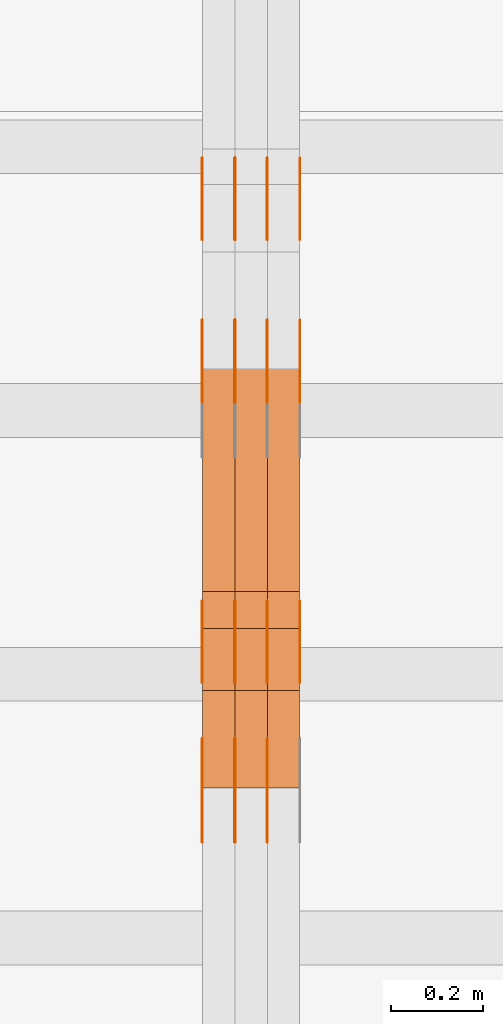
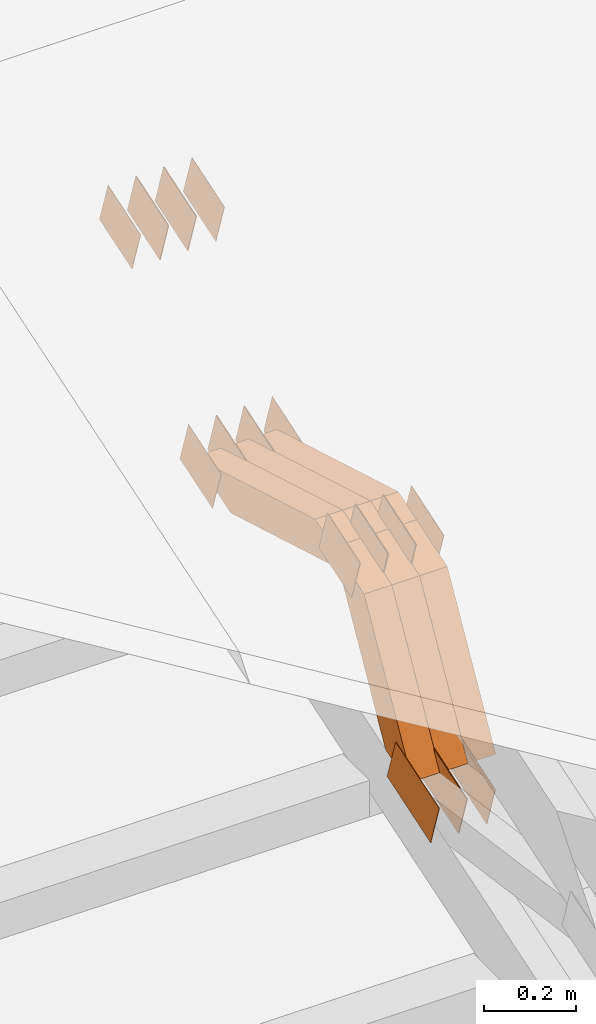
# One storey, part 109 of 385: 28 proxies.
"""IFC2X3 building model written with IfcOpenShell, lengths in millimetres."""

import ifcopenshell
import ifcopenshell.guid

model = None  # the IFC model being written
_history = None  # IfcOwnerHistory: only IFC2X3 demands one
_inside = {}  # id of a spatial element -> (the spatial element, [elements in it])
_under = {}  # id of a project, library or spatial element -> (it, [spatial elements below it])
_declared = {}  # id of a project -> (the project, [libraries it declares])
_typed = {}  # id of a type object -> (the type object, [elements of that type])
_made_of = {}  # id of a material, layer set ... -> (it, [elements and type objects made of it])


def new_model(schema):
    """Start an empty IFC model of exactly this schema.

    Asked for "IFC4X3", IfcOpenShell would pick the latest addendum, in which some entities
    have other attributes; the version numbers below select the first issue.
    IFC2X3 requires an IfcOwnerHistory on every rooted entity: one is made here for all.
    """
    global model, _history
    if schema == "IFC4X3":
        model = ifcopenshell.file(schema_version=(4, 3, 0, 0))
    else:
        model = ifcopenshell.file(schema=schema)
    _inside.clear()
    _under.clear()
    _declared.clear()
    _typed.clear()
    _made_of.clear()
    _history = None
    if model.schema == "IFC2X3":
        org = make("IfcOrganization", Name="unknown")
        user = make(
            "IfcPersonAndOrganization",
            ThePerson=make("IfcPerson", FamilyName="unknown"),
            TheOrganization=org,
        )
        app = make(
            "IfcApplication",
            ApplicationDeveloper=org,
            Version="unknown",
            ApplicationFullName="unknown",
            ApplicationIdentifier="unknown",
        )
        _history = make(
            "IfcOwnerHistory",
            OwningUser=user,
            OwningApplication=app,
            ChangeAction="ADDED",
            CreationDate=0,
        )
    return model


def make(cls, **values):
    """One entity of the class cls with the attributes given. An attribute that is None is left unset."""
    return model.create_entity(
        cls, **{name: value for name, value in values.items() if value is not None}
    )


def entity(cls, *values):
    """Any entity or typed value of the class cls, its attributes in the order of the schema. None: left unset."""
    e = model.create_entity(cls)
    for i, value in enumerate(values):
        if value is not None:
            e[i] = value
    return e


def rooted(cls, **values):
    """An entity with a GlobalId (a new one), such as an element, a storey or a relation."""
    return make(cls, GlobalId=ifcopenshell.guid.new(), OwnerHistory=_history, **values)


def si_unit(unit_type, name, prefix=None):
    """IfcSIUnit, for example si_unit("LENGTHUNIT", "METRE", prefix="MILLI")."""
    return make("IfcSIUnit", UnitType=unit_type, Prefix=prefix, Name=name)


def converted_unit(unit_type, name, factor, base, dimensions=None, offset=None):
    """IfcConversionBasedUnit, such as the inch: factor (a typed value) times the base unit."""
    return make(
        "IfcConversionBasedUnit"
        if offset is None
        else "IfcConversionBasedUnitWithOffset",
        ConversionOffset=offset,
        Dimensions=None
        if dimensions is None
        else entity("IfcDimensionalExponents", *dimensions),
        UnitType=unit_type,
        Name=name,
        ConversionFactor=make(
            "IfcMeasureWithUnit", ValueComponent=factor, UnitComponent=base
        ),
    )


def derived_unit(unit_type, elements):
    """IfcDerivedUnit: a product of units, each with its exponent."""
    return make(
        "IfcDerivedUnit",
        Elements=[
            make("IfcDerivedUnitElement", Unit=unit, Exponent=power)
            for unit, power in elements
        ],
        UnitType=unit_type,
    )


def assignment(units):
    """IfcUnitAssignment: the units of a project."""
    return None if units is None else make("IfcUnitAssignment", Units=units)


def point(xyz):
    """IfcCartesianPoint."""
    return None if xyz is None else make("IfcCartesianPoint", Coordinates=xyz)


def direction(xyz):
    """IfcDirection."""
    return None if xyz is None else make("IfcDirection", DirectionRatios=xyz)


def frame(location, z_axis=None, x_axis=None):
    """IfcAxis2Placement3D, a coordinate frame: its origin and axes. An axis left out is left unset."""
    return make(
        "IfcAxis2Placement3D",
        Location=point(location),
        Axis=direction(z_axis),
        RefDirection=direction(x_axis),
    )


def origin():
    """The frame at (0, 0, 0) with its axes left unset."""
    return frame((0.0, 0.0, 0.0))


def place(relative_to, where):
    """IfcLocalPlacement: puts the frame where relative to a parent placement (None: the world)."""
    return make(
        "IfcLocalPlacement", PlacementRelTo=relative_to, RelativePlacement=where
    )


def context(
    kind, dimensions, precision=None, world=None, true_north=None, identifier=None
):
    """IfcGeometricRepresentationContext, for example the 3D "Model" context."""
    return make(
        "IfcGeometricRepresentationContext",
        ContextIdentifier=identifier,
        ContextType=kind,
        CoordinateSpaceDimension=dimensions,
        Precision=precision,
        WorldCoordinateSystem=world,
        TrueNorth=true_north,
    )


def subcontext(parent, identifier, kind, view, scale=None):
    """IfcGeometricRepresentationSubContext, for example "Body" below "Model"."""
    return make(
        "IfcGeometricRepresentationSubContext",
        ContextIdentifier=identifier,
        ContextType=kind,
        ParentContext=parent,
        TargetScale=scale,
        TargetView=view,
    )


def project(units=None, contexts=None):
    """IfcProject with its units and contexts."""
    return rooted(
        "IfcProject",
        Name="project",
        RepresentationContexts=contexts,
        UnitsInContext=assignment(units),
    )


def spatial(cls, under=None, at=None, **own):
    """A site, building, storey or space (cls), placed at a placement, below another one or the project."""
    s = rooted(cls, ObjectPlacement=at, **own)
    if under is not None:
        _under.setdefault(under.id(), (under, []))[1].append(s)
    return s


def polyline(points):
    """IfcPolyline through the points."""
    return make("IfcPolyline", Points=[point(p) for p in points])


def outline(outer, holes=None, kind="AREA"):
    """IfcArbitraryClosedProfileDef: a profile drawn as a closed curve; with holes, ...WithVoids."""
    if holes is None:
        return make("IfcArbitraryClosedProfileDef", ProfileType=kind, OuterCurve=outer)
    return make(
        "IfcArbitraryProfileDefWithVoids",
        ProfileType=kind,
        OuterCurve=outer,
        InnerCurves=holes,
    )


def extrude(swept, where, along, depth):
    """IfcExtrudedAreaSolid: the profile swept, set in the frame where, extruded along a direction by depth."""
    return make(
        "IfcExtrudedAreaSolid",
        SweptArea=swept,
        Position=where,
        ExtrudedDirection=direction(along),
        Depth=depth,
    )


def shape(context_of_items, identifier, shape_type, items):
    """IfcShapeRepresentation: the items that make up one representation, for example the "Body"."""
    return make(
        "IfcShapeRepresentation",
        ContextOfItems=context_of_items,
        RepresentationIdentifier=identifier,
        RepresentationType=shape_type,
        Items=items,
    )


def source(mapping_origin, context_of_items, identifier, shape_type, items):
    """IfcRepresentationMap: a shape defined once, which mapped items show again and again."""
    return make(
        "IfcRepresentationMap",
        MappingOrigin=mapping_origin,
        MappedRepresentation=shape(context_of_items, identifier, shape_type, items),
    )


def transform(
    local_origin,
    x_axis=None,
    y_axis=None,
    z_axis=None,
    scale=None,
    scale2=None,
    scale3=None,
    uniform=True,
):
    """IfcCartesianTransformationOperator3D, or its non-uniform kind. x_axis, y_axis, z_axis: its Axis1, 2, 3."""
    if uniform:
        return make(
            "IfcCartesianTransformationOperator3D",
            Axis1=direction(x_axis),
            Axis2=direction(y_axis),
            LocalOrigin=point(local_origin),
            Scale=scale,
            Axis3=direction(z_axis),
        )
    return make(
        "IfcCartesianTransformationOperator3DnonUniform",
        Axis1=direction(x_axis),
        Axis2=direction(y_axis),
        LocalOrigin=point(local_origin),
        Scale=scale,
        Axis3=direction(z_axis),
        Scale2=scale2,
        Scale3=scale3,
    )


def mapped(mapping_source, mapping_target):
    """IfcMappedItem: shows the shape of a source again, moved by a transform."""
    return make(
        "IfcMappedItem", MappingSource=mapping_source, MappingTarget=mapping_target
    )


def material(Name=None, Category=None):
    """IfcMaterial."""
    return make("IfcMaterial", Name=Name, Category=Category)


def made_of(thing, what):
    """Note that an element or type object is made of a material, layer set ...; save() writes the relation."""
    if what is not None:
        _made_of.setdefault(what.id(), (what, []))[1].append(thing)
    return thing


def type_object(cls, material=None, **own):
    """A type object (cls), such as IfcWallType, which elements share."""
    return made_of(rooted(cls, **own), material)


def type_shapes(of_type, sources):
    """Give a type object the sources (RepresentationMaps) that its elements show as mapped items."""
    of_type.RepresentationMaps = sources


def element(
    cls,
    number,
    at=None,
    inside=None,
    cuts=None,
    type_object=None,
    material=None,
    context=None,
    identifier="Body",
    shape_type=None,
    held_by="IfcProductDefinitionShape",
    body=None,
    shapes=None,
    **own,
):
    """One element of the class cls, such as IfcWall. Its Tag is "e" and its number.

    at: its placement. inside: the storey or other place that contains it. cuts: it is an
    opening in that element (IfcRelVoidsElement). A single representation is given by context,
    identifier, shape_type and body (its items); several are given by shapes. held_by: the class
    of the entity that holds the representations. save() writes the other relations.
    """
    e = rooted(cls, Tag="e%d" % number, ObjectPlacement=at, **own)
    if body is not None:
        shapes = [shape(context, identifier, shape_type, body)]
    if shapes is not None:
        e.Representation = make(held_by, Representations=shapes)
    if inside is not None:
        _inside.setdefault(inside.id(), (inside, []))[1].append(e)
    if cuts is not None:
        rooted(
            "IfcRelVoidsElement", RelatingBuildingElement=cuts, RelatedOpeningElement=e
        )
    if type_object is not None:
        _typed.setdefault(type_object.id(), (type_object, []))[1].append(e)
    return made_of(e, material)


def aggregate(whole, parts):
    """IfcRelAggregates: a whole, such as a stair, and the parts it consists of."""
    return rooted("IfcRelAggregates", RelatingObject=whole, RelatedObjects=parts)


def save(model, path):
    """Write the relations noted so far, then the file.

    IfcRelAggregates (storeys below a building ...), IfcRelContainedInSpatialStructure (elements
    in a storey), IfcRelDefinesByType, IfcRelAssociatesMaterial and IfcRelDeclares: one each for
    every whole, place, type object, material and project.
    """
    for whole, parts in _under.values():
        aggregate(whole, parts)
    for where, things in _inside.values():
        rooted(
            "IfcRelContainedInSpatialStructure",
            RelatedElements=things,
            RelatingStructure=where,
        )
    for kind, things in _typed.values():
        rooted("IfcRelDefinesByType", RelatedObjects=things, RelatingType=kind)
    for what, things in _made_of.values():
        rooted("IfcRelAssociatesMaterial", RelatedObjects=things, RelatingMaterial=what)
    for by, libraries in _declared.values():
        rooted("IfcRelDeclares", RelatingContext=by, RelatedDefinitions=libraries)
    model.write(path)


model = new_model("IFC2X3")

# Units and contexts
model_context = context("Model", 3, precision=0.01, world=origin(), true_north=direction((6.12303176911189e-17, 1.0)))
body_context = subcontext(model_context, "Body", "Model", "MODEL_VIEW")
ifc_project = project(units=[si_unit("LENGTHUNIT", "METRE", prefix="MILLI"), si_unit("AREAUNIT", "SQUARE_METRE"), si_unit("VOLUMEUNIT", "CUBIC_METRE"), converted_unit("PLANEANGLEUNIT", "DEGREE", entity("IfcRatioMeasure", 0.0174532925199433), si_unit("PLANEANGLEUNIT", "RADIAN"), dimensions=[0, 0, 0, 0, 0, 0, 0]), si_unit("MASSUNIT", "GRAM", prefix="KILO"), derived_unit("MASSDENSITYUNIT", [(si_unit("MASSUNIT", "GRAM", prefix="KILO"), 1), (si_unit("LENGTHUNIT", "METRE"), -3)]), si_unit("TIMEUNIT", "SECOND"), si_unit("FREQUENCYUNIT", "HERTZ"), si_unit("THERMODYNAMICTEMPERATUREUNIT", "DEGREE_CELSIUS"), derived_unit("THERMALTRANSMITTANCEUNIT", [(si_unit("MASSUNIT", "GRAM", prefix="KILO"), 1), (si_unit("THERMODYNAMICTEMPERATUREUNIT", "KELVIN"), -1), (si_unit("TIMEUNIT", "SECOND"), -3)]), derived_unit("VOLUMETRICFLOWRATEUNIT", [(si_unit("LENGTHUNIT", "METRE"), 3), (si_unit("TIMEUNIT", "SECOND"), -1)]), si_unit("ELECTRICCURRENTUNIT", "AMPERE"), si_unit("ELECTRICVOLTAGEUNIT", "VOLT"), si_unit("POWERUNIT", "WATT"), si_unit("FORCEUNIT", "NEWTON", prefix="KILO"), si_unit("ILLUMINANCEUNIT", "LUX"), si_unit("LUMINOUSFLUXUNIT", "LUMEN"), si_unit("LUMINOUSINTENSITYUNIT", "CANDELA"), derived_unit("USERDEFINED", [(si_unit("MASSUNIT", "GRAM", prefix="KILO"), -1), (si_unit("LENGTHUNIT", "METRE"), -2), (si_unit("TIMEUNIT", "SECOND"), 3), (si_unit("LUMINOUSFLUXUNIT", "LUMEN"), 1)]), derived_unit("LINEARVELOCITYUNIT", [(si_unit("LENGTHUNIT", "METRE"), 1), (si_unit("TIMEUNIT", "SECOND"), -1)]), si_unit("PRESSUREUNIT", "PASCAL"), derived_unit("USERDEFINED", [(si_unit("LENGTHUNIT", "METRE"), -2), (si_unit("MASSUNIT", "GRAM", prefix="KILO"), 1), (si_unit("TIMEUNIT", "SECOND"), -2)])], contexts=[model_context])

# Site, building, storey
site_placement = place(None, origin())
site = spatial("IfcSite", under=ifc_project, at=site_placement, CompositionType="ELEMENT")
building_placement = place(site_placement, origin())
building = spatial("IfcBuilding", under=site, at=building_placement, CompositionType="ELEMENT")
storey_placement = place(building_placement, origin())
storey = spatial("IfcBuildingStorey", under=building, at=storey_placement, Name="Default", CompositionType="ELEMENT", Elevation=0.0)

# Proxies
ifc_material_1 = material(Name="IfcSurfaceStyle #236276")
building_element_proxy_type_1 = type_object("IfcBuildingElementProxyType", PredefinedType="NOTDEFINED", material=ifc_material_1)
shared_shape_1 = source(origin(), body_context, "Body", "SweptSolid", [
    extrude(outline(polyline([(-99.9998204243802, -60.000067376167), (99.9998338462265, -60.000067376167), (99.9998204243802, 60.000067376167), (-99.9998338462265, 60.000067376167), (-99.9998204243802, -60.000067376167)])), frame((100.000602015329, 60.0001864986889, 0.0), z_axis=(0.0, 0.0, 1.0), x_axis=(-1.0, 0.0, 0.0)), (0.0, 0.0, 1.0), 1.3),
])
type_shapes(building_element_proxy_type_1, [shared_shape_1])
proxy_1_placement = place(building_placement, frame((18316.3, 4114.85465165112, 513.097031388771), z_axis=(-1.0, 0.0, 0.0), x_axis=(0.0, 0.951056516295124, 0.309016994375039)))
element("IfcBuildingElementProxy", 1, at=proxy_1_placement, inside=storey, type_object=building_element_proxy_type_1, material=ifc_material_1, context=body_context, shape_type="MappedRepresentation", body=[
    mapped(shared_shape_1, transform((0.0, 0.0, 0.0), scale=1.0)),
])
ifc_material_2 = material(Name="IfcSurfaceStyle #236219")
building_element_proxy_type_2 = type_object("IfcBuildingElementProxyType", PredefinedType="NOTDEFINED", material=ifc_material_2)
shared_shape_2 = source(origin(), body_context, "Body", "SweptSolid", [
    extrude(outline(polyline([(-99.9998204243802, -60.000067376167), (99.9998338462265, -60.000067376167), (99.9998204243802, 60.000067376167), (-99.9998338462265, 60.000067376167), (-99.9998204243802, -60.000067376167)])), frame((100.000602015329, 60.0001864986889, 0.0), z_axis=(0.0, 0.0, 1.0), x_axis=(-1.0, 0.0, 0.0)), (0.0, 0.0, 1.0), 1.29999999999998),
])
type_shapes(building_element_proxy_type_2, [shared_shape_2])
proxy_2_placement = place(building_placement, frame((18245.0, 4114.85465165112, 513.097031388771), z_axis=(-1.0, 0.0, 0.0), x_axis=(0.0, 0.951056516295124, 0.309016994375039)))
element("IfcBuildingElementProxy", 2, at=proxy_2_placement, inside=storey, type_object=building_element_proxy_type_2, material=ifc_material_2, context=body_context, shape_type="MappedRepresentation", body=[
    mapped(shared_shape_2, transform((0.0, 0.0, 0.0), scale=1.0)),
])
ifc_material_3 = material(Name="IfcSurfaceStyle #236162")
building_element_proxy_type_3 = type_object("IfcBuildingElementProxyType", PredefinedType="NOTDEFINED", material=ifc_material_3)
shared_shape_3 = source(origin(), body_context, "Body", "SweptSolid", [
    extrude(outline(polyline([(-99.9998204243802, -60.000067376167), (99.9998338462265, -60.000067376167), (99.9998204243802, 60.000067376167), (-99.9998338462265, 60.000067376167), (-99.9998204243802, -60.000067376167)])), frame((100.000602015329, 60.0001864986889, 0.0), z_axis=(0.0, 0.0, 1.0), x_axis=(-1.0, 0.0, 0.0)), (0.0, 0.0, 1.0), 1.29999999999998),
])
type_shapes(building_element_proxy_type_3, [shared_shape_3])
proxy_3_placement = place(building_placement, frame((18246.3, 4114.85465165112, 513.097031388771), z_axis=(-1.0, 0.0, 0.0), x_axis=(0.0, 0.951056516295124, 0.309016994375039)))
element("IfcBuildingElementProxy", 3, at=proxy_3_placement, inside=storey, type_object=building_element_proxy_type_3, material=ifc_material_3, context=body_context, shape_type="MappedRepresentation", body=[
    mapped(shared_shape_3, transform((0.0, 0.0, 0.0), scale=1.0)),
])
ifc_material_4 = material(Name="IfcSurfaceStyle #236105")
building_element_proxy_type_4 = type_object("IfcBuildingElementProxyType", PredefinedType="NOTDEFINED", material=ifc_material_4)
shared_shape_4 = source(origin(), body_context, "Body", "SweptSolid", [
    extrude(outline(polyline([(-99.9998204243802, -60.000067376167), (99.9998338462265, -60.000067376167), (99.9998204243802, 60.000067376167), (-99.9998338462265, 60.000067376167), (-99.9998204243802, -60.000067376167)])), frame((100.000602015329, 60.0001864986889, 0.0), z_axis=(0.0, 0.0, 1.0), x_axis=(-1.0, 0.0, 0.0)), (0.0, 0.0, 1.0), 1.29999999999999),
])
type_shapes(building_element_proxy_type_4, [shared_shape_4])
proxy_4_placement = place(building_placement, frame((18175.0, 4114.85465165112, 513.097031388771), z_axis=(-1.0, 0.0, 0.0), x_axis=(0.0, 0.951056516295124, 0.309016994375039)))
element("IfcBuildingElementProxy", 4, at=proxy_4_placement, inside=storey, type_object=building_element_proxy_type_4, material=ifc_material_4, context=body_context, shape_type="MappedRepresentation", body=[
    mapped(shared_shape_4, transform((0.0, 0.0, 0.0), scale=1.0)),
])
ifc_material_5 = material(Name="IfcSurfaceStyle #236048")
building_element_proxy_type_5 = type_object("IfcBuildingElementProxyType", PredefinedType="NOTDEFINED", material=ifc_material_5)
shared_shape_5 = source(origin(), body_context, "Body", "SweptSolid", [
    extrude(outline(polyline([(-74.9998707133927, -60.0000596852269), (74.9998841352353, -60.0000596852269), (74.999861282944, 60.0000596852269), (-74.9998747047866, 60.0000596852269), (-74.9998707133927, -60.0000596852269)])), frame((74.9998841352353, 60.0000596852269, 0.0), z_axis=(0.0, 0.0, 1.0), x_axis=(-1.0, 0.0, 0.0)), (0.0, 0.0, 1.0), 1.3),
])
type_shapes(building_element_proxy_type_5, [shared_shape_5])
proxy_5_placement = place(building_placement, frame((18386.3, 5067.4882362875, 826.131473120182), z_axis=(-1.0, 0.0, 0.0), x_axis=(0.0, 0.951056516295124, 0.309016994375039)))
element("IfcBuildingElementProxy", 5, at=proxy_5_placement, inside=storey, type_object=building_element_proxy_type_5, material=ifc_material_5, context=body_context, shape_type="MappedRepresentation", body=[
    mapped(shared_shape_5, transform((0.0, 0.0, 0.0), scale=1.0)),
])
ifc_material_6 = material(Name="IfcSurfaceStyle #235991")
building_element_proxy_type_6 = type_object("IfcBuildingElementProxyType", PredefinedType="NOTDEFINED", material=ifc_material_6)
shared_shape_6 = source(origin(), body_context, "Body", "SweptSolid", [
    extrude(outline(polyline([(-74.9998707133927, -60.0000596852269), (74.9998841352353, -60.0000596852269), (74.999861282944, 60.0000596852269), (-74.9998747047866, 60.0000596852269), (-74.9998707133927, -60.0000596852269)])), frame((74.9998841352353, 60.0000596852269, 0.0), z_axis=(0.0, 0.0, 1.0), x_axis=(-1.0, 0.0, 0.0)), (0.0, 0.0, 1.0), 1.3),
])
type_shapes(building_element_proxy_type_6, [shared_shape_6])
proxy_6_placement = place(building_placement, frame((18315.0, 5067.4882362875, 826.131473120182), z_axis=(-1.0, 0.0, 0.0), x_axis=(0.0, 0.951056516295124, 0.309016994375039)))
element("IfcBuildingElementProxy", 6, at=proxy_6_placement, inside=storey, type_object=building_element_proxy_type_6, material=ifc_material_6, context=body_context, shape_type="MappedRepresentation", body=[
    mapped(shared_shape_6, transform((0.0, 0.0, 0.0), scale=1.0)),
])
ifc_material_7 = material(Name="IfcSurfaceStyle #235934")
building_element_proxy_type_7 = type_object("IfcBuildingElementProxyType", PredefinedType="NOTDEFINED", material=ifc_material_7)
shared_shape_7 = source(origin(), body_context, "Body", "SweptSolid", [
    extrude(outline(polyline([(-74.9998707133927, -60.0000596852269), (74.9998841352353, -60.0000596852269), (74.999861282944, 60.0000596852269), (-74.9998747047866, 60.0000596852269), (-74.9998707133927, -60.0000596852269)])), frame((74.9998841352353, 60.0000596852269, 0.0), z_axis=(0.0, 0.0, 1.0), x_axis=(-1.0, 0.0, 0.0)), (0.0, 0.0, 1.0), 1.3),
])
type_shapes(building_element_proxy_type_7, [shared_shape_7])
proxy_7_placement = place(building_placement, frame((18316.3, 5067.4882362875, 826.131473120182), z_axis=(-1.0, 0.0, 0.0), x_axis=(0.0, 0.951056516295124, 0.309016994375039)))
element("IfcBuildingElementProxy", 7, at=proxy_7_placement, inside=storey, type_object=building_element_proxy_type_7, material=ifc_material_7, context=body_context, shape_type="MappedRepresentation", body=[
    mapped(shared_shape_7, transform((0.0, 0.0, 0.0), scale=1.0)),
])
ifc_material_8 = material(Name="IfcSurfaceStyle #235877")
building_element_proxy_type_8 = type_object("IfcBuildingElementProxyType", PredefinedType="NOTDEFINED", material=ifc_material_8)
shared_shape_8 = source(origin(), body_context, "Body", "SweptSolid", [
    extrude(outline(polyline([(-74.9998707133927, -60.0000596852269), (74.9998841352353, -60.0000596852269), (74.999861282944, 60.0000596852269), (-74.9998747047866, 60.0000596852269), (-74.9998707133927, -60.0000596852269)])), frame((74.9998841352353, 60.0000596852269, 0.0), z_axis=(0.0, 0.0, 1.0), x_axis=(-1.0, 0.0, 0.0)), (0.0, 0.0, 1.0), 1.29999999999999),
])
type_shapes(building_element_proxy_type_8, [shared_shape_8])
proxy_8_placement = place(building_placement, frame((18245.0, 5067.4882362875, 826.131473120182), z_axis=(-1.0, 0.0, 0.0), x_axis=(0.0, 0.951056516295124, 0.309016994375039)))
element("IfcBuildingElementProxy", 8, at=proxy_8_placement, inside=storey, type_object=building_element_proxy_type_8, material=ifc_material_8, context=body_context, shape_type="MappedRepresentation", body=[
    mapped(shared_shape_8, transform((0.0, 0.0, 0.0), scale=1.0)),
])
ifc_material_9 = material(Name="IfcSurfaceStyle #235820")
building_element_proxy_type_9 = type_object("IfcBuildingElementProxyType", PredefinedType="NOTDEFINED", material=ifc_material_9)
shared_shape_9 = source(origin(), body_context, "Body", "SweptSolid", [
    extrude(outline(polyline([(-74.9998707133927, -60.0000596852269), (74.9998841352353, -60.0000596852269), (74.999861282944, 60.0000596852269), (-74.9998747047866, 60.0000596852269), (-74.9998707133927, -60.0000596852269)])), frame((74.9998841352353, 60.0000596852269, 0.0), z_axis=(0.0, 0.0, 1.0), x_axis=(-1.0, 0.0, 0.0)), (0.0, 0.0, 1.0), 1.29999999999999),
])
type_shapes(building_element_proxy_type_9, [shared_shape_9])
proxy_9_placement = place(building_placement, frame((18246.3, 5067.4882362875, 826.131473120182), z_axis=(-1.0, 0.0, 0.0), x_axis=(0.0, 0.951056516295124, 0.309016994375039)))
element("IfcBuildingElementProxy", 9, at=proxy_9_placement, inside=storey, type_object=building_element_proxy_type_9, material=ifc_material_9, context=body_context, shape_type="MappedRepresentation", body=[
    mapped(shared_shape_9, transform((0.0, 0.0, 0.0), scale=1.0)),
])
ifc_material_10 = material(Name="IfcSurfaceStyle #235763")
building_element_proxy_type_10 = type_object("IfcBuildingElementProxyType", PredefinedType="NOTDEFINED", material=ifc_material_10)
shared_shape_10 = source(origin(), body_context, "Body", "SweptSolid", [
    extrude(outline(polyline([(-74.9998707133927, -60.0000596852269), (74.9998841352353, -60.0000596852269), (74.999861282944, 60.0000596852269), (-74.9998747047866, 60.0000596852269), (-74.9998707133927, -60.0000596852269)])), frame((74.9998841352353, 60.0000596852269, 0.0), z_axis=(0.0, 0.0, 1.0), x_axis=(-1.0, 0.0, 0.0)), (0.0, 0.0, 1.0), 1.29999999999999),
])
type_shapes(building_element_proxy_type_10, [shared_shape_10])
proxy_10_placement = place(building_placement, frame((18175.0, 5067.4882362875, 826.131473120182), z_axis=(-1.0, 0.0, 0.0), x_axis=(0.0, 0.951056516295124, 0.309016994375039)))
element("IfcBuildingElementProxy", 10, at=proxy_10_placement, inside=storey, type_object=building_element_proxy_type_10, material=ifc_material_10, context=body_context, shape_type="MappedRepresentation", body=[
    mapped(shared_shape_10, transform((0.0, 0.0, 0.0), scale=1.0)),
])
ifc_material_11 = material(Name="IfcSurfaceStyle #230234")
building_element_proxy_type_11 = type_object("IfcBuildingElementProxyType", PredefinedType="NOTDEFINED", material=ifc_material_11)
shared_shape_11 = source(origin(), body_context, "Body", "SweptSolid", [
    extrude(outline(polyline([(-74.9998565677224, -60.0000596852342), (74.9998794200083, -60.0000596852342), (74.9998565677242, 60.0000596852342), (-74.9998794200101, 60.0000596852342), (-74.9998565677224, -60.0000596852342)])), frame((74.9998794200083, 60.0000596852342, 0.0), z_axis=(0.0, 0.0, 1.0), x_axis=(-1.0, 0.0, 0.0)), (0.0, 0.0, 1.0), 1.3),
])
type_shapes(building_element_proxy_type_11, [shared_shape_11])
proxy_11_placement = place(building_placement, frame((18386.3, 5418.6991737875, 1250.81341892098), z_axis=(-1.0, 0.0, 0.0), x_axis=(0.0, 0.951056516295154, 0.309016994374948)))
element("IfcBuildingElementProxy", 11, at=proxy_11_placement, inside=storey, type_object=building_element_proxy_type_11, material=ifc_material_11, context=body_context, shape_type="MappedRepresentation", body=[
    mapped(shared_shape_11, transform((0.0, 0.0, 0.0), scale=1.0)),
])
ifc_material_12 = material(Name="IfcSurfaceStyle #230177")
building_element_proxy_type_12 = type_object("IfcBuildingElementProxyType", PredefinedType="NOTDEFINED", material=ifc_material_12)
shared_shape_12 = source(origin(), body_context, "Body", "SweptSolid", [
    extrude(outline(polyline([(-74.9998565677224, -60.0000596852342), (74.9998794200083, -60.0000596852342), (74.9998565677242, 60.0000596852342), (-74.9998794200101, 60.0000596852342), (-74.9998565677224, -60.0000596852342)])), frame((74.9998794200083, 60.0000596852342, 0.0), z_axis=(0.0, 0.0, 1.0), x_axis=(-1.0, 0.0, 0.0)), (0.0, 0.0, 1.0), 1.3),
])
type_shapes(building_element_proxy_type_12, [shared_shape_12])
proxy_12_placement = place(building_placement, frame((18315.0, 5418.6991737875, 1250.81341892098), z_axis=(-1.0, 0.0, 0.0), x_axis=(0.0, 0.951056516295154, 0.309016994374948)))
element("IfcBuildingElementProxy", 12, at=proxy_12_placement, inside=storey, type_object=building_element_proxy_type_12, material=ifc_material_12, context=body_context, shape_type="MappedRepresentation", body=[
    mapped(shared_shape_12, transform((0.0, 0.0, 0.0), scale=1.0)),
])
ifc_material_13 = material(Name="IfcSurfaceStyle #230120")
building_element_proxy_type_13 = type_object("IfcBuildingElementProxyType", PredefinedType="NOTDEFINED", material=ifc_material_13)
shared_shape_13 = source(origin(), body_context, "Body", "SweptSolid", [
    extrude(outline(polyline([(-74.9998565677224, -60.0000596852342), (74.9998794200083, -60.0000596852342), (74.9998565677242, 60.0000596852342), (-74.9998794200101, 60.0000596852342), (-74.9998565677224, -60.0000596852342)])), frame((74.9998794200083, 60.0000596852342, 0.0), z_axis=(0.0, 0.0, 1.0), x_axis=(-1.0, 0.0, 0.0)), (0.0, 0.0, 1.0), 1.3),
])
type_shapes(building_element_proxy_type_13, [shared_shape_13])
proxy_13_placement = place(building_placement, frame((18316.3, 5418.6991737875, 1250.81341892098), z_axis=(-1.0, 0.0, 0.0), x_axis=(0.0, 0.951056516295154, 0.309016994374948)))
element("IfcBuildingElementProxy", 13, at=proxy_13_placement, inside=storey, type_object=building_element_proxy_type_13, material=ifc_material_13, context=body_context, shape_type="MappedRepresentation", body=[
    mapped(shared_shape_13, transform((0.0, 0.0, 0.0), scale=1.0)),
])
ifc_material_14 = material(Name="IfcSurfaceStyle #230063")
building_element_proxy_type_14 = type_object("IfcBuildingElementProxyType", PredefinedType="NOTDEFINED", material=ifc_material_14)
shared_shape_14 = source(origin(), body_context, "Body", "SweptSolid", [
    extrude(outline(polyline([(-74.9998565677224, -60.0000596852342), (74.9998794200083, -60.0000596852342), (74.9998565677242, 60.0000596852342), (-74.9998794200101, 60.0000596852342), (-74.9998565677224, -60.0000596852342)])), frame((74.9998794200083, 60.0000596852342, 0.0), z_axis=(0.0, 0.0, 1.0), x_axis=(-1.0, 0.0, 0.0)), (0.0, 0.0, 1.0), 1.29999999999999),
])
type_shapes(building_element_proxy_type_14, [shared_shape_14])
proxy_14_placement = place(building_placement, frame((18245.0, 5418.6991737875, 1250.81341892098), z_axis=(-1.0, 0.0, 0.0), x_axis=(0.0, 0.951056516295154, 0.309016994374948)))
element("IfcBuildingElementProxy", 14, at=proxy_14_placement, inside=storey, type_object=building_element_proxy_type_14, material=ifc_material_14, context=body_context, shape_type="MappedRepresentation", body=[
    mapped(shared_shape_14, transform((0.0, 0.0, 0.0), scale=1.0)),
])
ifc_material_15 = material(Name="IfcSurfaceStyle #230006")
building_element_proxy_type_15 = type_object("IfcBuildingElementProxyType", PredefinedType="NOTDEFINED", material=ifc_material_15)
shared_shape_15 = source(origin(), body_context, "Body", "SweptSolid", [
    extrude(outline(polyline([(-74.9998565677224, -60.0000596852342), (74.9998794200083, -60.0000596852342), (74.9998565677242, 60.0000596852342), (-74.9998794200101, 60.0000596852342), (-74.9998565677224, -60.0000596852342)])), frame((74.9998794200083, 60.0000596852342, 0.0), z_axis=(0.0, 0.0, 1.0), x_axis=(-1.0, 0.0, 0.0)), (0.0, 0.0, 1.0), 1.29999999999999),
])
type_shapes(building_element_proxy_type_15, [shared_shape_15])
proxy_15_placement = place(building_placement, frame((18246.3, 5418.6991737875, 1250.81341892098), z_axis=(-1.0, 0.0, 0.0), x_axis=(0.0, 0.951056516295154, 0.309016994374948)))
element("IfcBuildingElementProxy", 15, at=proxy_15_placement, inside=storey, type_object=building_element_proxy_type_15, material=ifc_material_15, context=body_context, shape_type="MappedRepresentation", body=[
    mapped(shared_shape_15, transform((0.0, 0.0, 0.0), scale=1.0)),
])
ifc_material_16 = material(Name="IfcSurfaceStyle #229949")
building_element_proxy_type_16 = type_object("IfcBuildingElementProxyType", PredefinedType="NOTDEFINED", material=ifc_material_16)
shared_shape_16 = source(origin(), body_context, "Body", "SweptSolid", [
    extrude(outline(polyline([(-74.9998565677224, -60.0000596852342), (74.9998794200083, -60.0000596852342), (74.9998565677242, 60.0000596852342), (-74.9998794200101, 60.0000596852342), (-74.9998565677224, -60.0000596852342)])), frame((74.9998794200083, 60.0000596852342, 0.0), z_axis=(0.0, 0.0, 1.0), x_axis=(-1.0, 0.0, 0.0)), (0.0, 0.0, 1.0), 1.29999999999999),
])
type_shapes(building_element_proxy_type_16, [shared_shape_16])
proxy_16_placement = place(building_placement, frame((18175.0, 5418.6991737875, 1250.81341892098), z_axis=(-1.0, 0.0, 0.0), x_axis=(0.0, 0.951056516295154, 0.309016994374948)))
element("IfcBuildingElementProxy", 16, at=proxy_16_placement, inside=storey, type_object=building_element_proxy_type_16, material=ifc_material_16, context=body_context, shape_type="MappedRepresentation", body=[
    mapped(shared_shape_16, transform((0.0, 0.0, 0.0), scale=1.0)),
])
ifc_material_17 = material(Name="IfcSurfaceStyle #229208")
building_element_proxy_type_17 = type_object("IfcBuildingElementProxyType", PredefinedType="NOTDEFINED", material=ifc_material_17)
shared_shape_17 = source(origin(), body_context, "Body", "SweptSolid", [
    extrude(outline(polyline([(-74.999865998172, -60.0000306612919), (74.999869989555, -60.0000306612919), (74.999865998172, 60.0000306612919), (-74.999869989555, 60.0000306612919), (-74.999865998172, -60.0000306612919)])), frame((75.0006726017528, 60.0001996460842, 0.0), z_axis=(0.0, 0.0, 1.0), x_axis=(-1.0, 0.0, 0.0)), (0.0, 0.0, 1.0), 1.3),
])
type_shapes(building_element_proxy_type_17, [shared_shape_17])
proxy_17_placement = place(building_placement, frame((18386.3, 4460.38978242656, 957.314497110567), z_axis=(-1.0, 0.0, 0.0), x_axis=(0.0, 0.951056516295154, 0.309016994374948)))
element("IfcBuildingElementProxy", 17, at=proxy_17_placement, inside=storey, type_object=building_element_proxy_type_17, material=ifc_material_17, context=body_context, shape_type="MappedRepresentation", body=[
    mapped(shared_shape_17, transform((0.0, 0.0, 0.0), scale=1.0)),
])
ifc_material_18 = material(Name="IfcSurfaceStyle #229151")
building_element_proxy_type_18 = type_object("IfcBuildingElementProxyType", PredefinedType="NOTDEFINED", material=ifc_material_18)
shared_shape_18 = source(origin(), body_context, "Body", "SweptSolid", [
    extrude(outline(polyline([(-74.999865998172, -60.0000306612919), (74.999869989555, -60.0000306612919), (74.999865998172, 60.0000306612919), (-74.999869989555, 60.0000306612919), (-74.999865998172, -60.0000306612919)])), frame((75.0006726017528, 60.0001996460842, 0.0), z_axis=(0.0, 0.0, 1.0), x_axis=(-1.0, 0.0, 0.0)), (0.0, 0.0, 1.0), 1.3),
])
type_shapes(building_element_proxy_type_18, [shared_shape_18])
proxy_18_placement = place(building_placement, frame((18315.0, 4460.38978242656, 957.314497110567), z_axis=(-1.0, 0.0, 0.0), x_axis=(0.0, 0.951056516295154, 0.309016994374948)))
element("IfcBuildingElementProxy", 18, at=proxy_18_placement, inside=storey, type_object=building_element_proxy_type_18, material=ifc_material_18, context=body_context, shape_type="MappedRepresentation", body=[
    mapped(shared_shape_18, transform((0.0, 0.0, 0.0), scale=1.0)),
])
ifc_material_19 = material(Name="IfcSurfaceStyle #229094")
building_element_proxy_type_19 = type_object("IfcBuildingElementProxyType", PredefinedType="NOTDEFINED", material=ifc_material_19)
shared_shape_19 = source(origin(), body_context, "Body", "SweptSolid", [
    extrude(outline(polyline([(-74.999865998172, -60.0000306612919), (74.999869989555, -60.0000306612919), (74.999865998172, 60.0000306612919), (-74.999869989555, 60.0000306612919), (-74.999865998172, -60.0000306612919)])), frame((75.0006726017528, 60.0001996460842, 0.0), z_axis=(0.0, 0.0, 1.0), x_axis=(-1.0, 0.0, 0.0)), (0.0, 0.0, 1.0), 1.3),
])
type_shapes(building_element_proxy_type_19, [shared_shape_19])
proxy_19_placement = place(building_placement, frame((18316.3, 4460.38978242656, 957.314497110567), z_axis=(-1.0, 0.0, 0.0), x_axis=(0.0, 0.951056516295154, 0.309016994374948)))
element("IfcBuildingElementProxy", 19, at=proxy_19_placement, inside=storey, type_object=building_element_proxy_type_19, material=ifc_material_19, context=body_context, shape_type="MappedRepresentation", body=[
    mapped(shared_shape_19, transform((0.0, 0.0, 0.0), scale=1.0)),
])
ifc_material_20 = material(Name="IfcSurfaceStyle #229037")
building_element_proxy_type_20 = type_object("IfcBuildingElementProxyType", PredefinedType="NOTDEFINED", material=ifc_material_20)
shared_shape_20 = source(origin(), body_context, "Body", "SweptSolid", [
    extrude(outline(polyline([(-74.999865998172, -60.0000306612919), (74.999869989555, -60.0000306612919), (74.999865998172, 60.0000306612919), (-74.999869989555, 60.0000306612919), (-74.999865998172, -60.0000306612919)])), frame((75.0006726017528, 60.0001996460842, 0.0), z_axis=(0.0, 0.0, 1.0), x_axis=(-1.0, 0.0, 0.0)), (0.0, 0.0, 1.0), 1.29999999999999),
])
type_shapes(building_element_proxy_type_20, [shared_shape_20])
proxy_20_placement = place(building_placement, frame((18245.0, 4460.38978242656, 957.314497110567), z_axis=(-1.0, 0.0, 0.0), x_axis=(0.0, 0.951056516295154, 0.309016994374948)))
element("IfcBuildingElementProxy", 20, at=proxy_20_placement, inside=storey, type_object=building_element_proxy_type_20, material=ifc_material_20, context=body_context, shape_type="MappedRepresentation", body=[
    mapped(shared_shape_20, transform((0.0, 0.0, 0.0), scale=1.0)),
])
ifc_material_21 = material(Name="IfcSurfaceStyle #228980")
building_element_proxy_type_21 = type_object("IfcBuildingElementProxyType", PredefinedType="NOTDEFINED", material=ifc_material_21)
shared_shape_21 = source(origin(), body_context, "Body", "SweptSolid", [
    extrude(outline(polyline([(-74.999865998172, -60.0000306612919), (74.999869989555, -60.0000306612919), (74.999865998172, 60.0000306612919), (-74.999869989555, 60.0000306612919), (-74.999865998172, -60.0000306612919)])), frame((75.0006726017528, 60.0001996460842, 0.0), z_axis=(0.0, 0.0, 1.0), x_axis=(-1.0, 0.0, 0.0)), (0.0, 0.0, 1.0), 1.29999999999999),
])
type_shapes(building_element_proxy_type_21, [shared_shape_21])
proxy_21_placement = place(building_placement, frame((18246.3, 4460.38978242656, 957.314497110567), z_axis=(-1.0, 0.0, 0.0), x_axis=(0.0, 0.951056516295154, 0.309016994374948)))
element("IfcBuildingElementProxy", 21, at=proxy_21_placement, inside=storey, type_object=building_element_proxy_type_21, material=ifc_material_21, context=body_context, shape_type="MappedRepresentation", body=[
    mapped(shared_shape_21, transform((0.0, 0.0, 0.0), scale=1.0)),
])
ifc_material_22 = material(Name="IfcSurfaceStyle #228923")
building_element_proxy_type_22 = type_object("IfcBuildingElementProxyType", PredefinedType="NOTDEFINED", material=ifc_material_22)
shared_shape_22 = source(origin(), body_context, "Body", "SweptSolid", [
    extrude(outline(polyline([(-74.999865998172, -60.0000306612919), (74.999869989555, -60.0000306612919), (74.999865998172, 60.0000306612919), (-74.999869989555, 60.0000306612919), (-74.999865998172, -60.0000306612919)])), frame((75.0006726017528, 60.0001996460842, 0.0), z_axis=(0.0, 0.0, 1.0), x_axis=(-1.0, 0.0, 0.0)), (0.0, 0.0, 1.0), 1.29999999999999),
])
type_shapes(building_element_proxy_type_22, [shared_shape_22])
proxy_22_placement = place(building_placement, frame((18175.0, 4460.38978242656, 957.314497110567), z_axis=(-1.0, 0.0, 0.0), x_axis=(0.0, 0.951056516295154, 0.309016994374948)))
element("IfcBuildingElementProxy", 22, at=proxy_22_placement, inside=storey, type_object=building_element_proxy_type_22, material=ifc_material_22, context=body_context, shape_type="MappedRepresentation", body=[
    mapped(shared_shape_22, transform((0.0, 0.0, 0.0), scale=1.0)),
])
ifc_material_23 = material(Name="IfcSurfaceStyle #216680")
building_element_proxy_type_23 = type_object("IfcBuildingElementProxyType", Name="T1-W12 216678", PredefinedType="NOTDEFINED", material=ifc_material_23)
shared_shape_23 = source(origin(), body_context, "Body", "SweptSolid", [
    extrude(outline(polyline([(-249.405625983165, -47.5001691155616), (243.345753908996, -47.5001691155616), (232.115534842595, 2.39993474701938e-05), (162.527010966644, 47.5001571158879), (-388.58267373507, 47.5001571158879), (-249.405625983165, -47.5001691155616)])), frame((243.345867653852, 47.5001571158879, 0.0), z_axis=(0.0, 0.0, 1.0), x_axis=(-1.0, 0.0, 0.0)), (0.0, 0.0, 1.0), 70.0),
])
type_shapes(building_element_proxy_type_23, [shared_shape_23])
proxy_23_placement = place(building_placement, frame((18385.0, 4581.32698473631, 976.172276753357), z_axis=(-1.0, 0.0, 0.0), x_axis=(0.0, 0.959722067881787, -0.280951156645966)))
element("IfcBuildingElementProxy", 23, at=proxy_23_placement, inside=storey, type_object=building_element_proxy_type_23, material=ifc_material_23, Name="T1-W12", context=body_context, shape_type="MappedRepresentation", body=[
    mapped(shared_shape_23, transform((0.0, 0.0, 0.0), scale=1.0)),
])
ifc_material_24 = material(Name="IfcSurfaceStyle #216614")
building_element_proxy_type_24 = type_object("IfcBuildingElementProxyType", Name="T1-W12 216612", PredefinedType="NOTDEFINED", material=ifc_material_24)
shared_shape_24 = source(origin(), body_context, "Body", "SweptSolid", [
    extrude(outline(polyline([(-249.405625983165, -47.5001691155616), (243.345753908996, -47.5001691155616), (232.115534842595, 2.39993474701938e-05), (162.527010966644, 47.5001571158879), (-388.58267373507, 47.5001571158879), (-249.405625983165, -47.5001691155616)])), frame((243.345867653852, 47.5001571158879, 0.0), z_axis=(0.0, 0.0, 1.0), x_axis=(-1.0, 0.0, 0.0)), (0.0, 0.0, 1.0), 70.0),
])
type_shapes(building_element_proxy_type_24, [shared_shape_24])
proxy_24_placement = place(building_placement, frame((18315.0, 4581.32698473631, 976.172276753357), z_axis=(-1.0, 0.0, 0.0), x_axis=(0.0, 0.959722067881787, -0.280951156645966)))
element("IfcBuildingElementProxy", 24, at=proxy_24_placement, inside=storey, type_object=building_element_proxy_type_24, material=ifc_material_24, Name="T1-W12", context=body_context, shape_type="MappedRepresentation", body=[
    mapped(shared_shape_24, transform((0.0, 0.0, 0.0), scale=1.0)),
])
ifc_material_25 = material(Name="IfcSurfaceStyle #216548")
building_element_proxy_type_25 = type_object("IfcBuildingElementProxyType", Name="T1-W12 216546", PredefinedType="NOTDEFINED", material=ifc_material_25)
shared_shape_25 = source(origin(), body_context, "Body", "SweptSolid", [
    extrude(outline(polyline([(-249.405625983165, -47.5001691155616), (243.345753908996, -47.5001691155616), (232.115534842595, 2.39993474701938e-05), (162.527010966644, 47.5001571158879), (-388.58267373507, 47.5001571158879), (-249.405625983165, -47.5001691155616)])), frame((243.345867653852, 47.5001571158879, 0.0), z_axis=(0.0, 0.0, 1.0), x_axis=(-1.0, 0.0, 0.0)), (0.0, 0.0, 1.0), 70.0),
])
type_shapes(building_element_proxy_type_25, [shared_shape_25])
proxy_25_placement = place(building_placement, frame((18245.0, 4581.32698473631, 976.172276753357), z_axis=(-1.0, 0.0, 0.0), x_axis=(0.0, 0.959722067881787, -0.280951156645966)))
element("IfcBuildingElementProxy", 25, at=proxy_25_placement, inside=storey, type_object=building_element_proxy_type_25, material=ifc_material_25, Name="T1-W12", context=body_context, shape_type="MappedRepresentation", body=[
    mapped(shared_shape_25, transform((0.0, 0.0, 0.0), scale=1.0)),
])
ifc_material_26 = material(Name="IfcSurfaceStyle #216284")
building_element_proxy_type_26 = type_object("IfcBuildingElementProxyType", Name="T1-W27 216282", PredefinedType="NOTDEFINED", material=ifc_material_26)
shared_shape_26 = source(origin(), body_context, "Body", "SweptSolid", [
    extrude(outline(polyline([(-321.979763159708, -47.49993999164), (138.960018341432, -47.49993999164), (191.013775341887, -0.000473170132329126), (209.87827169492, 47.5001765767061), (-217.872302218531, 47.5001765767062), (-321.979763159708, -47.49993999164)])), frame((209.87827169492, 47.5001765767061, 0.0), z_axis=(0.0, 0.0, 1.0), x_axis=(-1.0, 0.0, 0.0)), (0.0, 0.0, 1.0), 70.0),
])
type_shapes(building_element_proxy_type_26, [shared_shape_26])
proxy_26_placement = place(building_placement, frame((18385.0, 4233.3125, 512.021728515625), z_axis=(-1.0, 0.0, 0.0), x_axis=(0.0, 0.494231057369727, 0.869330582650352)))
element("IfcBuildingElementProxy", 26, at=proxy_26_placement, inside=storey, type_object=building_element_proxy_type_26, material=ifc_material_26, Name="T1-W27", context=body_context, shape_type="MappedRepresentation", body=[
    mapped(shared_shape_26, transform((0.0, 0.0, 0.0), scale=1.0)),
])
ifc_material_27 = material(Name="IfcSurfaceStyle #216218")
building_element_proxy_type_27 = type_object("IfcBuildingElementProxyType", Name="T1-W27 216216", PredefinedType="NOTDEFINED", material=ifc_material_27)
shared_shape_27 = source(origin(), body_context, "Body", "SweptSolid", [
    extrude(outline(polyline([(-321.979763159708, -47.49993999164), (138.960018341432, -47.49993999164), (191.013775341887, -0.000473170132329126), (209.87827169492, 47.5001765767061), (-217.872302218531, 47.5001765767062), (-321.979763159708, -47.49993999164)])), frame((209.87827169492, 47.5001765767061, 0.0), z_axis=(0.0, 0.0, 1.0), x_axis=(-1.0, 0.0, 0.0)), (0.0, 0.0, 1.0), 70.0),
])
type_shapes(building_element_proxy_type_27, [shared_shape_27])
proxy_27_placement = place(building_placement, frame((18315.0, 4233.3125, 512.021728515625), z_axis=(-1.0, 0.0, 0.0), x_axis=(0.0, 0.494231057369727, 0.869330582650352)))
element("IfcBuildingElementProxy", 27, at=proxy_27_placement, inside=storey, type_object=building_element_proxy_type_27, material=ifc_material_27, Name="T1-W27", context=body_context, shape_type="MappedRepresentation", body=[
    mapped(shared_shape_27, transform((0.0, 0.0, 0.0), scale=1.0)),
])
ifc_material_28 = material(Name="IfcSurfaceStyle #216152")
building_element_proxy_type_28 = type_object("IfcBuildingElementProxyType", Name="T1-W27 216150", PredefinedType="NOTDEFINED", material=ifc_material_28)
shared_shape_28 = source(origin(), body_context, "Body", "SweptSolid", [
    extrude(outline(polyline([(-321.979763159708, -47.49993999164), (138.960018341432, -47.49993999164), (191.013775341887, -0.000473170132329126), (209.87827169492, 47.5001765767061), (-217.872302218531, 47.5001765767062), (-321.979763159708, -47.49993999164)])), frame((209.87827169492, 47.5001765767061, 0.0), z_axis=(0.0, 0.0, 1.0), x_axis=(-1.0, 0.0, 0.0)), (0.0, 0.0, 1.0), 70.0),
])
type_shapes(building_element_proxy_type_28, [shared_shape_28])
proxy_28_placement = place(building_placement, frame((18245.0, 4233.3125, 512.021728515625), z_axis=(-1.0, 0.0, 0.0), x_axis=(0.0, 0.494231057369727, 0.869330582650352)))
element("IfcBuildingElementProxy", 28, at=proxy_28_placement, inside=storey, type_object=building_element_proxy_type_28, material=ifc_material_28, Name="T1-W27", context=body_context, shape_type="MappedRepresentation", body=[
    mapped(shared_shape_28, transform((0.0, 0.0, 0.0), scale=1.0)),
])

save(model, "model.ifc")
